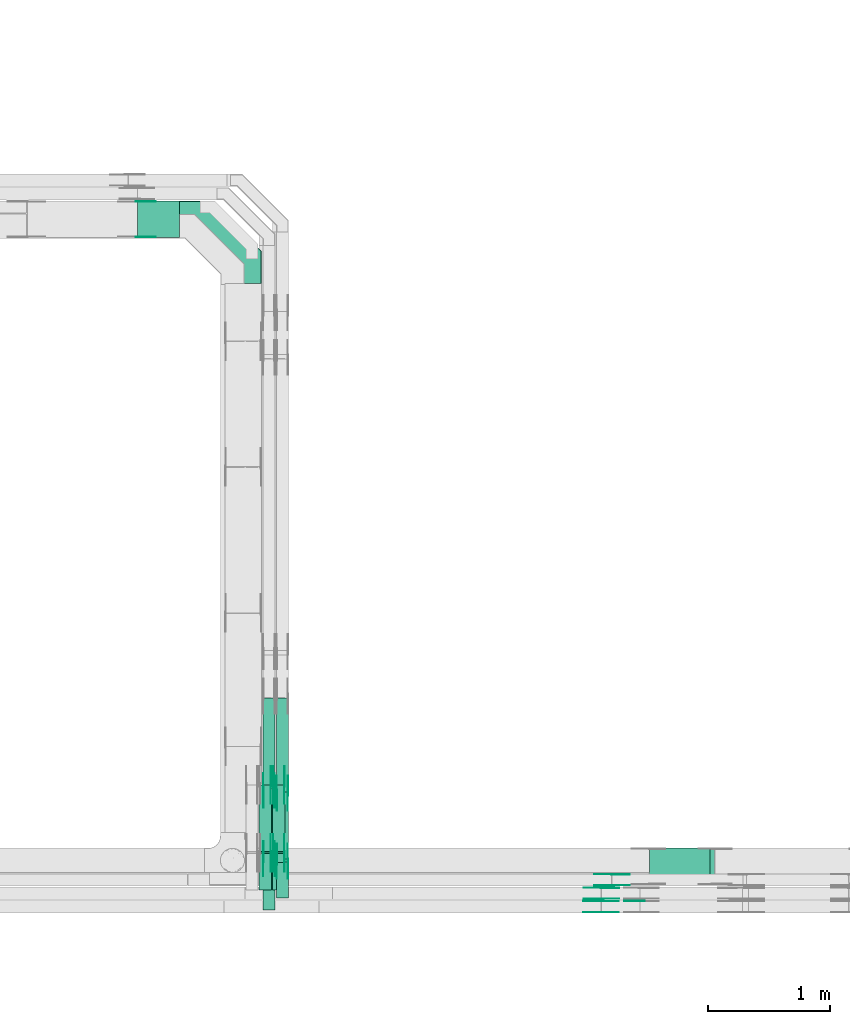
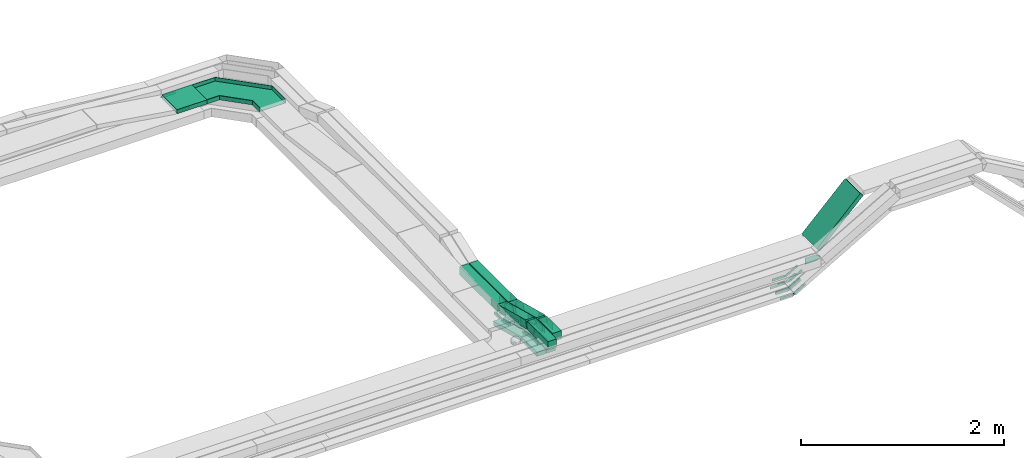
# One storey, part 25 of 33: 44 flow fittings, 12 flow segments.
"""IFC2X3 building model written with IfcOpenShell, lengths in millimetres."""

from ifc_helpers import new_model, entity, si_unit, converted_unit, derived_unit, direction, frame, frame_2d, origin, place, context, subcontext, project, spatial, polyline, circle_curve, parameter, trimmed, segment, composite_curve, rectangle, outline, extrude, faceted_brep, source, transform, mapped, material, type_object, type_shapes, element, save


model = new_model("IFC2X3")

# Units and contexts
model_context = context("Model", 3, precision=0.01, world=origin(), true_north=direction((6.12303176911189e-17, 1.0)))
body_context = subcontext(model_context, "Body", "Model", "MODEL_VIEW")
ifc_project = project(units=[si_unit("LENGTHUNIT", "METRE", prefix="MILLI"), si_unit("AREAUNIT", "SQUARE_METRE"), si_unit("VOLUMEUNIT", "CUBIC_METRE"), converted_unit("PLANEANGLEUNIT", "DEGREE", entity("IfcRatioMeasure", 0.0174532925199433), si_unit("PLANEANGLEUNIT", "RADIAN"), dimensions=[0, 0, 0, 0, 0, 0, 0]), si_unit("MASSUNIT", "GRAM", prefix="KILO"), derived_unit("MASSDENSITYUNIT", [(si_unit("MASSUNIT", "GRAM", prefix="KILO"), 1), (si_unit("LENGTHUNIT", "METRE"), -3)]), derived_unit("MOMENTOFINERTIAUNIT", [(si_unit("LENGTHUNIT", "METRE"), 4)]), si_unit("TIMEUNIT", "SECOND"), si_unit("FREQUENCYUNIT", "HERTZ"), si_unit("THERMODYNAMICTEMPERATUREUNIT", "DEGREE_CELSIUS"), derived_unit("THERMALTRANSMITTANCEUNIT", [(si_unit("MASSUNIT", "GRAM", prefix="KILO"), 1), (si_unit("THERMODYNAMICTEMPERATUREUNIT", "KELVIN"), -1), (si_unit("TIMEUNIT", "SECOND"), -3)]), derived_unit("VOLUMETRICFLOWRATEUNIT", [(si_unit("LENGTHUNIT", "METRE"), 3), (si_unit("TIMEUNIT", "SECOND"), -1)]), derived_unit("MASSFLOWRATEUNIT", [(si_unit("MASSUNIT", "GRAM", prefix="KILO"), 1), (si_unit("TIMEUNIT", "SECOND"), -1)]), derived_unit("ROTATIONALFREQUENCYUNIT", [(si_unit("TIMEUNIT", "SECOND"), -1)]), si_unit("ELECTRICCURRENTUNIT", "AMPERE"), si_unit("ELECTRICVOLTAGEUNIT", "VOLT"), si_unit("POWERUNIT", "WATT"), si_unit("FORCEUNIT", "NEWTON", prefix="KILO"), si_unit("ILLUMINANCEUNIT", "LUX"), si_unit("LUMINOUSFLUXUNIT", "LUMEN"), si_unit("LUMINOUSINTENSITYUNIT", "CANDELA"), derived_unit("USERDEFINED", [(si_unit("MASSUNIT", "GRAM", prefix="KILO"), -1), (si_unit("LENGTHUNIT", "METRE"), -2), (si_unit("TIMEUNIT", "SECOND"), 3), (si_unit("LUMINOUSFLUXUNIT", "LUMEN"), 1)]), derived_unit("LINEARVELOCITYUNIT", [(si_unit("LENGTHUNIT", "METRE"), 1), (si_unit("TIMEUNIT", "SECOND"), -1)]), si_unit("PRESSUREUNIT", "PASCAL"), derived_unit("USERDEFINED", [(si_unit("LENGTHUNIT", "METRE"), -2), (si_unit("MASSUNIT", "GRAM", prefix="KILO"), 1), (si_unit("TIMEUNIT", "SECOND"), -2)]), derived_unit("LINEARFORCEUNIT", [(si_unit("MASSUNIT", "GRAM", prefix="KILO"), 1), (si_unit("LENGTHUNIT", "METRE"), 1), (si_unit("TIMEUNIT", "SECOND"), -2), (si_unit("LENGTHUNIT", "METRE"), -1)]), derived_unit("PLANARFORCEUNIT", [(si_unit("MASSUNIT", "GRAM", prefix="KILO"), 1), (si_unit("LENGTHUNIT", "METRE"), 1), (si_unit("TIMEUNIT", "SECOND"), -2), (si_unit("LENGTHUNIT", "METRE"), -2)])], contexts=[model_context])

# Site, building, storey
site_placement = place(None, frame((0.0, -0.00077364408347762, 0.0)))
site = spatial("IfcSite", under=ifc_project, at=site_placement, CompositionType="ELEMENT")
building_placement = place(site_placement, origin())
building = spatial("IfcBuilding", under=site, at=building_placement, CompositionType="ELEMENT")
storey_placement = place(building_placement, frame((0.0, 0.0, 8100.0)))
storey = spatial("IfcBuildingStorey", under=building, at=storey_placement, CompositionType="ELEMENT", Elevation=8100.0)

# Flow segments
cable_carrier_segment_type = type_object("IfcCableCarrierSegmentType", PredefinedType="CABLETRAYSEGMENT")
flow_segment_1_placement = place(storey_placement, frame((63784.3788258892, 8869.97860618826, 2805.44313627274)))
element("IfcFlowSegment", 1, at=flow_segment_1_placement, inside=storey, type_object=cable_carrier_segment_type, context=body_context, shape_type="SweptSolid", body=[
    extrude(rectangle(XDim=50.000000000011, YDim=299.999999999999, at=frame_2d((-7.65609797781508e-13, 0.0), x_axis=(1.0, 0.0))), frame((17.6776695296773, 150.0, 17.6776695296687), z_axis=(0.707106781186504, 0.0, 0.707106781186591), x_axis=(-0.707106781186591, 0.0, 0.707106781186504)), (0.0, 0.0, 1.0), 699.790262425115),
])
flow_segment_2_placement = place(storey_placement, frame((60610.1085349485, 8663.58444205874, 2864.77838120979)))
element("IfcFlowSegment", 2, at=flow_segment_2_placement, inside=storey, type_object=cable_carrier_segment_type, context=body_context, shape_type="SweptSolid", body=[
    extrude(rectangle(XDim=409.510534279909, YDim=99.9999999999946, at=frame_2d((5.40012479177676e-13, 8.66506866259442e-12), x_axis=(1.0, 0.0))), frame((50.0, 204.755267139955, 0.0), z_axis=(0.0, 0.0, 1.0), x_axis=(0.0, -1.0, 0.0)), (0.0, 0.0, 1.0), 99.9999999999989),
])
flow_segment_3_placement = place(storey_placement, frame((60610.1085349485, 9076.08577980001, 2718.78565933378)))
element("IfcFlowSegment", 3, at=flow_segment_3_placement, inside=storey, type_object=cable_carrier_segment_type, context=body_context, shape_type="SweptSolid", body=[
    extrude(rectangle(XDim=99.9999999999971, YDim=99.9999999999946, at=frame_2d((-8.66506866259442e-12, 0.0), x_axis=(0.0, 1.0))), frame((50.0, 12.8016957729536, 193.93674912082), z_axis=(0.0, 0.966667799264408, -0.25603391545908), x_axis=(-1.0, 0.0, 0.0)), (0.0, 0.0, 1.0), 568.687780665809),
])
flow_segment_4_placement = place(storey_placement, frame((60720.1085349485, 8762.62949966908, 2864.81248367712)))
element("IfcFlowSegment", 4, at=flow_segment_4_placement, inside=storey, type_object=cable_carrier_segment_type, context=body_context, shape_type="SweptSolid", body=[
    extrude(rectangle(XDim=289.519566739919, YDim=99.9999999999946, at=frame_2d((5.40012479177676e-13, 8.66506866259442e-12), x_axis=(1.0, 0.0))), frame((50.0, 144.759783369959, 0.0), z_axis=(0.0, 0.0, 1.0), x_axis=(0.0, -1.0, 0.0)), (0.0, 0.0, 1.0), 99.9999999999989),
])
flow_segment_5_placement = place(storey_placement, frame((60720.1085349485, 9055.13986987036, 2718.82215415974)))
element("IfcFlowSegment", 5, at=flow_segment_5_placement, inside=storey, type_object=cable_carrier_segment_type, context=body_context, shape_type="SweptSolid", body=[
    extrude(rectangle(XDim=99.9999999999987, YDim=99.9999999999946, at=frame_2d((-8.66506866259442e-12, 0.0), x_axis=(0.0, 1.0))), frame((50.0, 12.8016957729579, 193.934356762171), z_axis=(0.0, 0.966667799264392, -0.25603391545914), x_axis=(-1.0, 0.0, 0.0)), (0.0, 0.0, 1.0), 568.678436752631),
])
flow_segment_6_placement = place(storey_placement, frame((60720.1085349493, 9633.45677814429, 2715.09535929605)))
element("IfcFlowSegment", 6, at=flow_segment_6_placement, inside=storey, type_object=cable_carrier_segment_type, context=body_context, shape_type="SweptSolid", body=[
    extrude(rectangle(XDim=769.369188674836, YDim=99.9999999985392, at=frame_2d((-5.6843418860808e-13, 0.0), x_axis=(1.0, 0.0))), frame((50.0, 384.684594331773, 0.00208428287731977), z_axis=(0.0, 5.41816050582133e-06, 1.0), x_axis=(0.0, 1.0, -5.41816050582133e-06)), (0.0, 0.0, 1.0), 99.99999999853),
])
flow_segment_7_placement = place(storey_placement, frame((60610.1085349485, 9654.41214021207, 2715.06307654166)))
element("IfcFlowSegment", 7, at=flow_segment_7_placement, inside=storey, type_object=cable_carrier_segment_type, context=body_context, shape_type="SweptSolid", body=[
    extrude(rectangle(XDim=748.425977553941, YDim=99.9999999999946, at=frame_2d((2.18847162614111e-12, 0.0), x_axis=(1.0, 0.0))), frame((50.0, 374.212988776977, 0.0), z_axis=(0.0, 0.0, 1.0), x_axis=(0.0, -1.0, 0.0)), (0.0, 0.0, 1.0), 99.9999999999968),
])
flow_segment_8_placement = place(storey_placement, frame((60690.1085349485, 8826.02609150699, 2697.68139712069)))
element("IfcFlowSegment", 8, at=flow_segment_8_placement, inside=storey, type_object=cable_carrier_segment_type, context=body_context, shape_type="SweptSolid", body=[
    extrude(rectangle(XDim=300.444409805727, YDim=99.9999999999946, at=frame_2d((-5.40012479177676e-13, 0.0), x_axis=(1.0, 0.0))), frame((50.0, 150.222204902864, 0.0), z_axis=(0.0, 0.0, 1.0), x_axis=(0.0, -1.0, 0.0)), (0.0, 0.0, 1.0), 50.0000000000016),
])
flow_segment_9_placement = place(storey_placement, frame((60690.1085349485, 9129.46130477396, 2552.05597275502)))
element("IfcFlowSegment", 9, at=flow_segment_9_placement, inside=storey, type_object=cable_carrier_segment_type, context=body_context, shape_type="SweptSolid", body=[
    extrude(rectangle(XDim=50.0000000000033, YDim=567.25321482059, at=frame_2d((0.0, 0.0), x_axis=(0.0, 1.0))), frame((0.0, 280.573556284615, 96.7847258052534), z_axis=(1.0, 0.0, 0.0), x_axis=(0.0, 0.966667799264399, -0.256033915459111)), (0.0, 0.0, 1.0), 99.9999999999946),
])
flow_segment_10_placement = place(storey_placement, frame((60580.1085349485, 8826.02609150699, 2697.68139712068)))
element("IfcFlowSegment", 10, at=flow_segment_10_placement, inside=storey, type_object=cable_carrier_segment_type, context=body_context, shape_type="SweptSolid", body=[
    extrude(rectangle(XDim=300.444409805722, YDim=99.9999999999946, at=frame_2d((-5.40012479177676e-13, 0.0), x_axis=(1.0, 0.0))), frame((50.0, 150.222204902862, 0.0), z_axis=(0.0, 0.0, 1.0), x_axis=(0.0, -1.0, 0.0)), (0.0, 0.0, 1.0), 50.0000000000016),
])
flow_segment_11_placement = place(storey_placement, frame((60580.1085349485, 9129.46130477395, 2552.055972755)))
element("IfcFlowSegment", 11, at=flow_segment_11_placement, inside=storey, type_object=cable_carrier_segment_type, context=body_context, shape_type="SweptSolid", body=[
    extrude(rectangle(XDim=50.0000000000033, YDim=567.253214820593, at=frame_2d((5.40012479177676e-13, 1.4033219031262e-13), x_axis=(0.0, 1.0))), frame((0.0, 280.573556284615, 96.7847258052534), z_axis=(1.0, 0.0, 0.0), x_axis=(0.0, 0.9666677992644, -0.256033915459109)), (0.0, 0.0, 1.0), 99.9999999999946),
])
flow_segment_12_placement = place(storey_placement, frame((59581.8230685685, 14182.2782357481, 2714.71648655331)))
element("IfcFlowSegment", 12, at=flow_segment_12_placement, inside=storey, type_object=cable_carrier_segment_type, context=body_context, shape_type="SweptSolid", body=[
    extrude(rectangle(XDim=342.285466379996, YDim=300.000000000001, at=frame_2d((0.0, -1.08002495835535e-12), x_axis=(1.0, 0.0))), frame((171.142733189998, 150.0, 0.0)), (0.0, 0.0, 1.0), 50.0000000000016),
])

# Flow fittings
ifc_material_1 = material(Name="G")
cable_carrier_fitting_type_1 = type_object("IfcCableCarrierFittingType", PredefinedType="NOTDEFINED", material=ifc_material_1)
shared_shape_1 = source(origin(), body_context, "Body", "SweptSolid", [
    extrude(outline(composite_curve([segment(trimmed(circle_curve(frame_2d((-44.5901162790698, 0.0), x_axis=(1.0, 0.0)), 12.5), [parameter(90.0000000000007)], [parameter(270.0)], True, "PARAMETER"), True, "CONTINUOUS"), segment(polyline([(-44.5901162790697, -12.5), (-33.0901162790698, -12.5)]), True, "CONTINUOUS"), segment(polyline([(-33.0901162790698, -12.5), (-31.2296511627907, -14.5)]), True, "CONTINUOUS"), segment(polyline([(-31.2296511627907, -14.5), (108.90988372093, -14.5)]), True, "CONTINUOUS"), segment(polyline([(108.90988372093, -14.5), (108.90988372093, 14.5)]), True, "CONTINUOUS"), segment(polyline([(108.90988372093, 14.5), (-31.2296511627907, 14.5)]), True, "CONTINUOUS"), segment(polyline([(-31.2296511627907, 14.5), (-33.0901162790698, 12.5)]), True, "CONTINUOUS"), segment(polyline([(-33.0901162790698, 12.5), (-44.5901162790699, 12.5)]), True, "CONTINUOUS")], self_intersect=False)), frame((44.5901162790698, 0.0, 0.0), z_axis=(0.0, 0.0, -1.0), x_axis=(1.0, 0.0, 0.0)), (0.0, 0.0, -1.0), 2.0),
])
type_shapes(cable_carrier_fitting_type_1, [shared_shape_1])
for number, where, z_axis, x_axis in (
    (13, (60785.5685349586, 9131.2459145021, 2722.68139712075), (1.0, 0.0, 0.0), (0.0, -1.0, 0.0)),
    (14, (60675.5685349586, 9131.2459145021, 2722.68139712074), (1.0, 0.0, 0.0), (0.0, -1.0, 0.0)),
    (15, (60675.5685349586, 9688.82380761497, 2575.0), (1.0, 0.0, 0.0), (0.0, 1.0, 0.0)),
    (16, (60785.5685349586, 9688.82380761497, 2575.0), (1.0, 0.0, 0.0), (0.0, 1.0, 0.0)),
    (17, (63481.7964990867, 8955.43860619837, 2574.87332137862), (0.0, 1.0, 0.0), (-1.0, 0.0, 0.0)),
    (18, (63395.1341032399, 8845.43860619837, 2574.8693455352), (0.0, 1.0, 0.0), (-1.0, 0.0, 0.0)),
    (19, (63392.1739116772, 8735.44005286093, 2573.15905189633), (0.0, 1.0, 0.0), (-1.0, 0.0, 0.0)),
    (20, (59578.6062108725, 14186.818235738, 2739.7164865533), (0.0, -1.0, 0.0), (1.0, 0.0, 0.0)),
):
    element("IfcFlowFitting", number, at=place(storey_placement, frame(where, z_axis=z_axis, x_axis=x_axis)), inside=storey, type_object=cable_carrier_fitting_type_1, material=ifc_material_1, context=body_context, shape_type="MappedRepresentation", body=[
        mapped(shared_shape_1, transform((0.0, 0.0, 0.0), scale=1.0)),
    ])
cable_carrier_fitting_type_2 = type_object("IfcCableCarrierFittingType", PredefinedType="NOTDEFINED", material=ifc_material_1)
shared_shape_2 = source(origin(), body_context, "Body", "SweptSolid", [
    extrude(outline(composite_curve([segment(trimmed(circle_curve(frame_2d((-44.5901162790697, 0.0), x_axis=(1.0, 0.0)), 12.5), [parameter(90.0000000000007)], [parameter(270.0)], True, "PARAMETER"), True, "CONTINUOUS"), segment(polyline([(-44.5901162790697, -12.5), (-33.0901162790697, -12.5)]), True, "CONTINUOUS"), segment(polyline([(-33.0901162790697, -12.5), (-31.2296511627907, -14.5)]), True, "CONTINUOUS"), segment(polyline([(-31.2296511627907, -14.5), (108.90988372093, -14.5)]), True, "CONTINUOUS"), segment(polyline([(108.90988372093, -14.5), (108.90988372093, 14.5)]), True, "CONTINUOUS"), segment(polyline([(108.90988372093, 14.5), (-31.2296511627907, 14.5)]), True, "CONTINUOUS"), segment(polyline([(-31.2296511627907, 14.5), (-33.0901162790698, 12.5)]), True, "CONTINUOUS"), segment(polyline([(-33.0901162790698, 12.5), (-44.5901162790699, 12.5)]), True, "CONTINUOUS")], self_intersect=False)), frame((44.5901162790697, 0.0, 0.0)), (0.0, 0.0, 1.0), 2.0),
])
type_shapes(cable_carrier_fitting_type_2, [shared_shape_2])
for number, where, z_axis, x_axis in (
    (21, (60694.6485349383, 9131.24591450211, 2722.68139712076), (-1.0, 0.0, 0.0), (0.0, -1.0, 0.0)),
    (22, (60694.6485349383, 9688.82380761497, 2575.0), (-1.0, 0.0, 0.0), (0.0, 1.0, 0.0)),
    (23, (63481.7964990867, 8864.51860617805, 2574.87332137861), (0.0, -1.0, 0.0), (-1.0, 0.0, 0.0)),
    (24, (63395.1341032399, 8754.51860617806, 2574.8693455352), (0.0, -1.0, 0.0), (-1.0, 0.0, 0.0)),
    (25, (63392.1739116772, 8644.52005284061, 2573.15905189633), (0.0, -1.0, 0.0), (-1.0, 0.0, 0.0)),
    (26, (59578.6062108725, 14477.7382357583, 2739.7164865533), (0.0, 1.0, 0.0), (1.0, 0.0, 0.0)),
):
    element("IfcFlowFitting", number, at=place(storey_placement, frame(where, z_axis=z_axis, x_axis=x_axis)), inside=storey, type_object=cable_carrier_fitting_type_2, material=ifc_material_1, context=body_context, shape_type="MappedRepresentation", body=[
        mapped(shared_shape_2, transform((0.0, 0.0, 0.0), scale=1.0)),
    ])
cable_carrier_fitting_type_3 = type_object("IfcCableCarrierFittingType", PredefinedType="NOTDEFINED", material=ifc_material_1)
shared_shape_3 = source(origin(), body_context, "Body", "SweptSolid", [
    extrude(outline(composite_curve([segment(trimmed(circle_curve(frame_2d((-44.5901162790698, 0.0), x_axis=(1.0, 0.0)), 12.5), [parameter(90.0000000000007)], [parameter(270.0)], True, "PARAMETER"), True, "CONTINUOUS"), segment(polyline([(-44.5901162790697, -12.5), (-33.0901162790698, -12.5)]), True, "CONTINUOUS"), segment(polyline([(-33.0901162790698, -12.5), (-31.2296511627907, -14.5)]), True, "CONTINUOUS"), segment(polyline([(-31.2296511627907, -14.5), (108.90988372093, -14.5)]), True, "CONTINUOUS"), segment(polyline([(108.90988372093, -14.5), (108.90988372093, 14.5)]), True, "CONTINUOUS"), segment(polyline([(108.90988372093, 14.5), (-31.2296511627907, 14.5)]), True, "CONTINUOUS"), segment(polyline([(-31.2296511627907, 14.5), (-33.0901162790698, 12.5)]), True, "CONTINUOUS"), segment(polyline([(-33.0901162790698, 12.5), (-44.5901162790699, 12.5)]), True, "CONTINUOUS")], self_intersect=False)), frame((44.5901162790698, 0.0, 0.0), z_axis=(0.0, 0.0, -1.0), x_axis=(1.0, 0.0, 0.0)), (0.0, 0.0, -1.0), 2.0),
])
type_shapes(cable_carrier_fitting_type_3, [shared_shape_3])
for number, where, z_axis, x_axis in (
    (27, (60696.6485349383, 9131.24591450209, 2722.68139712076), (-1.0, 0.0, 0.0), (0.0, 0.966667799263134, -0.256033915463888)),
    (28, (60696.6485349383, 9688.82380761499, 2575.0), (-1.0, 0.0, 0.0), (0.0, -0.966667799264405, 0.256033915459091)),
    (29, (63481.7964990867, 8866.51860617805, 2574.87332137861), (0.0, -1.0, 0.0), (0.866025403784435, 0.0, 0.500000000000007)),
    (30, (63395.1341032399, 8756.51860617806, 2574.8693455352), (0.0, -1.0, 0.0), (0.866025403784431, 0.0, 0.500000000000014)),
    (31, (63392.1739116772, 8646.52005284061, 2573.15905189633), (0.0, -1.0, 0.0), (0.866025403784416, 0.0, 0.500000000000039)),
):
    element("IfcFlowFitting", number, at=place(storey_placement, frame(where, z_axis=z_axis, x_axis=x_axis)), inside=storey, type_object=cable_carrier_fitting_type_3, material=ifc_material_1, context=body_context, shape_type="MappedRepresentation", body=[
        mapped(shared_shape_3, transform((0.0, 0.0, 0.0), scale=1.0)),
    ])
cable_carrier_fitting_type_4 = type_object("IfcCableCarrierFittingType", PredefinedType="NOTDEFINED", material=ifc_material_1)
shared_shape_4 = source(origin(), body_context, "Body", "SweptSolid", [
    extrude(outline(composite_curve([segment(trimmed(circle_curve(frame_2d((-44.5901162790697, 0.0), x_axis=(1.0, 0.0)), 12.5), [parameter(90.0000000000007)], [parameter(270.0)], True, "PARAMETER"), True, "CONTINUOUS"), segment(polyline([(-44.5901162790697, -12.5), (-33.0901162790697, -12.5)]), True, "CONTINUOUS"), segment(polyline([(-33.0901162790697, -12.5), (-31.2296511627907, -14.5)]), True, "CONTINUOUS"), segment(polyline([(-31.2296511627907, -14.5), (108.90988372093, -14.5)]), True, "CONTINUOUS"), segment(polyline([(108.90988372093, -14.5), (108.90988372093, 14.5)]), True, "CONTINUOUS"), segment(polyline([(108.90988372093, 14.5), (-31.2296511627907, 14.5)]), True, "CONTINUOUS"), segment(polyline([(-31.2296511627907, 14.5), (-33.0901162790698, 12.5)]), True, "CONTINUOUS"), segment(polyline([(-33.0901162790698, 12.5), (-44.5901162790699, 12.5)]), True, "CONTINUOUS")], self_intersect=False)), frame((44.5901162790697, 0.0, 0.0)), (0.0, 0.0, 1.0), 2.0),
])
type_shapes(cable_carrier_fitting_type_4, [shared_shape_4])
for number, where, z_axis, x_axis in (
    (32, (60783.5685349586, 9131.24591450209, 2722.68139712075), (1.0, 0.0, 0.0), (0.0, 0.966667799263134, -0.256033915463888)),
    (33, (60673.5685349586, 9131.24591450208, 2722.68139712073), (1.0, 0.0, 0.0), (0.0, 0.966667799263134, -0.256033915463888)),
    (34, (60673.5685349586, 9688.82380761499, 2575.0), (1.0, 0.0, 0.0), (0.0, -0.966667799264405, 0.256033915459089)),
    (35, (60783.5685349586, 9688.82380761499, 2575.0), (1.0, 0.0, 0.0), (0.0, -0.966667799264405, 0.256033915459091)),
    (36, (63481.7964990867, 8953.43860619837, 2574.87332137862), (0.0, 1.0, 0.0), (0.866025403784435, 0.0, 0.500000000000007)),
    (37, (63395.1341032399, 8843.43860619837, 2574.8693455352), (0.0, 1.0, 0.0), (0.866025403784431, 0.0, 0.500000000000014)),
    (38, (63392.1739116772, 8733.44005286093, 2573.15905189633), (0.0, 1.0, 0.0), (0.866025403784416, 0.0, 0.500000000000039)),
):
    element("IfcFlowFitting", number, at=place(storey_placement, frame(where, z_axis=z_axis, x_axis=x_axis)), inside=storey, type_object=cable_carrier_fitting_type_4, material=ifc_material_1, context=body_context, shape_type="MappedRepresentation", body=[
        mapped(shared_shape_4, transform((0.0, 0.0, 0.0), scale=1.0)),
    ])
cable_carrier_fitting_type_5 = type_object("IfcCableCarrierFittingType", PredefinedType="NOTDEFINED", material=ifc_material_1)
shared_shape_5 = source(origin(), body_context, "Body", "SweptSolid", [
    extrude(outline(composite_curve([segment(trimmed(circle_curve(frame_2d((-41.4651162790697, 0.0), x_axis=(1.0, 0.0)), 25.0), [parameter(90.0000000000007)], [parameter(270.0)], True, "PARAMETER"), True, "CONTINUOUS"), segment(polyline([(-41.4651162790697, -25.0), (-29.9651162790697, -25.0)]), True, "CONTINUOUS"), segment(polyline([(-29.9651162790697, -25.0), (-28.1046511627907, -38.5)]), True, "CONTINUOUS"), segment(polyline([(-28.1046511627907, -38.5), (99.5348837209303, -38.5)]), True, "CONTINUOUS"), segment(polyline([(99.5348837209303, -38.5), (99.5348837209303, 38.5)]), True, "CONTINUOUS"), segment(polyline([(99.5348837209303, 38.5), (-28.1046511627907, 38.5)]), True, "CONTINUOUS"), segment(polyline([(-28.1046511627907, 38.5), (-29.9651162790697, 25.0)]), True, "CONTINUOUS"), segment(polyline([(-29.9651162790697, 25.0), (-41.46511627907, 25.0)]), True, "CONTINUOUS")], self_intersect=False)), frame((41.4651162790697, 0.0, 0.0), z_axis=(0.0, 0.0, -1.0), x_axis=(1.0, 0.0, 0.0)), (0.0, 0.0, -1.0), 2.0),
])
type_shapes(cable_carrier_fitting_type_5, [shared_shape_5])
for number, where, z_axis, x_axis in (
    (39, (60705.5685349587, 9081.1250560706, 2914.77838120986), (1.0, 0.0, 0.0), (0.0, -1.0, 0.0)),
    (40, (60815.5685349587, 9060.17914614095, 2914.81248367717), (1.0, 0.0, 0.0), (0.0, -1.0, 0.0)),
    (41, (60705.5685349587, 9646.38206048012, 2765.06307654178), (1.0, 0.0, 0.0), (0.0, 1.0, 0.0)),
    (42, (60815.5685349587, 9625.42711809031, 2765.09957136777), (1.0, 0.0, 0.0), (0.0, 1.0, -5.41816542959372e-06)),
    (43, (63717.4196649966, 8735.43859023208, 2849.49286701191), (0.0, 1.0, 0.0), (-1.0, 0.0, 0.0)),
):
    element("IfcFlowFitting", number, at=place(storey_placement, frame(where, z_axis=z_axis, x_axis=x_axis)), inside=storey, type_object=cable_carrier_fitting_type_5, material=ifc_material_1, context=body_context, shape_type="MappedRepresentation", body=[
        mapped(shared_shape_5, transform((0.0, 0.0, 0.0), scale=1.0)),
    ])
cable_carrier_fitting_type_6 = type_object("IfcCableCarrierFittingType", PredefinedType="NOTDEFINED", material=ifc_material_1)
shared_shape_6 = source(origin(), body_context, "Body", "SweptSolid", [
    extrude(outline(composite_curve([segment(trimmed(circle_curve(frame_2d((-41.4651162790697, 0.0), x_axis=(1.0, 0.0)), 25.0), [parameter(90.0000000000007)], [parameter(270.0)], True, "PARAMETER"), True, "CONTINUOUS"), segment(polyline([(-41.4651162790697, -25.0), (-29.9651162790697, -25.0)]), True, "CONTINUOUS"), segment(polyline([(-29.9651162790697, -25.0), (-28.1046511627907, -38.5)]), True, "CONTINUOUS"), segment(polyline([(-28.1046511627907, -38.5), (99.5348837209303, -38.5)]), True, "CONTINUOUS"), segment(polyline([(99.5348837209303, -38.5), (99.5348837209303, 38.5)]), True, "CONTINUOUS"), segment(polyline([(99.5348837209303, 38.5), (-28.1046511627907, 38.5)]), True, "CONTINUOUS"), segment(polyline([(-28.1046511627907, 38.5), (-29.9651162790697, 25.0)]), True, "CONTINUOUS"), segment(polyline([(-29.9651162790697, 25.0), (-41.46511627907, 25.0)]), True, "CONTINUOUS")], self_intersect=False)), frame((41.4651162790697, 0.0, 0.0)), (0.0, 0.0, 1.0), 2.0),
])
type_shapes(cable_carrier_fitting_type_6, [shared_shape_6])
for number, where, z_axis, x_axis in (
    (44, (60614.6485349384, 9081.1250560706, 2914.77838120988), (-1.0, 0.0, 0.0), (0.0, -1.0, 0.0)),
    (45, (60724.6485349384, 9060.17914614095, 2914.81248367719), (-1.0, 0.0, 0.0), (0.0, -1.0, 0.0)),
    (46, (60614.6485349384, 9646.38206048012, 2765.06307654178), (-1.0, 0.0, 0.0), (0.0, 1.0, 0.0)),
    (47, (60724.6485349384, 9625.42711809031, 2765.09957136777), (-1.0, 0.0, 0.0), (0.0, 1.0, -5.41816542959372e-06)),
):
    element("IfcFlowFitting", number, at=place(storey_placement, frame(where, z_axis=z_axis, x_axis=x_axis)), inside=storey, type_object=cable_carrier_fitting_type_6, material=ifc_material_1, context=body_context, shape_type="MappedRepresentation", body=[
        mapped(shared_shape_6, transform((0.0, 0.0, 0.0), scale=1.0)),
    ])
cable_carrier_fitting_type_7 = type_object("IfcCableCarrierFittingType", PredefinedType="NOTDEFINED", material=ifc_material_1)
shared_shape_7 = source(origin(), body_context, "Body", "SweptSolid", [
    extrude(outline(composite_curve([segment(trimmed(circle_curve(frame_2d((-41.4651162790697, 0.0), x_axis=(1.0, 0.0)), 25.0), [parameter(90.0000000000007)], [parameter(270.0)], True, "PARAMETER"), True, "CONTINUOUS"), segment(polyline([(-41.4651162790697, -25.0), (-29.9651162790697, -25.0)]), True, "CONTINUOUS"), segment(polyline([(-29.9651162790697, -25.0), (-28.1046511627907, -38.5)]), True, "CONTINUOUS"), segment(polyline([(-28.1046511627907, -38.5), (99.5348837209303, -38.5)]), True, "CONTINUOUS"), segment(polyline([(99.5348837209303, -38.5), (99.5348837209303, 38.5)]), True, "CONTINUOUS"), segment(polyline([(99.5348837209303, 38.5), (-28.1046511627907, 38.5)]), True, "CONTINUOUS"), segment(polyline([(-28.1046511627907, 38.5), (-29.9651162790697, 25.0)]), True, "CONTINUOUS"), segment(polyline([(-29.9651162790697, 25.0), (-41.46511627907, 25.0)]), True, "CONTINUOUS")], self_intersect=False)), frame((41.4651162790697, 0.0, 0.0), z_axis=(0.0, 0.0, -1.0), x_axis=(1.0, 0.0, 0.0)), (0.0, 0.0, -1.0), 2.0),
])
type_shapes(cable_carrier_fitting_type_7, [shared_shape_7])
for number, where, z_axis, x_axis in (
    (48, (60616.6485349384, 9081.12505607058, 2914.77838120988), (-1.0, 0.0, 0.0), (0.0, 0.966667799263134, -0.256033915463888)),
    (49, (60726.6485349384, 9060.17914614093, 2914.81248367718), (-1.0, 0.0, 0.0), (0.0, 0.966667799263134, -0.256033915463888)),
    (50, (60616.6485349384, 9646.38206048014, 2765.06307654178), (-1.0, 0.0, 0.0), (0.0, -0.966667799264413, 0.256033915459061)),
    (51, (60726.6485349384, 9625.42711809033, 2765.09957136777), (-1.0, 0.0, 0.0), (0.0, -0.966667799264395, 0.256033915459125)),
):
    element("IfcFlowFitting", number, at=place(storey_placement, frame(where, z_axis=z_axis, x_axis=x_axis)), inside=storey, type_object=cable_carrier_fitting_type_7, material=ifc_material_1, context=body_context, shape_type="MappedRepresentation", body=[
        mapped(shared_shape_7, transform((0.0, 0.0, 0.0), scale=1.0)),
    ])
cable_carrier_fitting_type_8 = type_object("IfcCableCarrierFittingType", PredefinedType="NOTDEFINED", material=ifc_material_1)
shared_shape_8 = source(origin(), body_context, "Body", "SweptSolid", [
    extrude(outline(composite_curve([segment(trimmed(circle_curve(frame_2d((-41.4651162790697, 0.0), x_axis=(1.0, 0.0)), 25.0), [parameter(90.0000000000007)], [parameter(270.0)], True, "PARAMETER"), True, "CONTINUOUS"), segment(polyline([(-41.4651162790697, -25.0), (-29.9651162790697, -25.0)]), True, "CONTINUOUS"), segment(polyline([(-29.9651162790697, -25.0), (-28.1046511627907, -38.5)]), True, "CONTINUOUS"), segment(polyline([(-28.1046511627907, -38.5), (99.5348837209303, -38.5)]), True, "CONTINUOUS"), segment(polyline([(99.5348837209303, -38.5), (99.5348837209303, 38.5)]), True, "CONTINUOUS"), segment(polyline([(99.5348837209303, 38.5), (-28.1046511627907, 38.5)]), True, "CONTINUOUS"), segment(polyline([(-28.1046511627907, 38.5), (-29.9651162790697, 25.0)]), True, "CONTINUOUS"), segment(polyline([(-29.9651162790697, 25.0), (-41.46511627907, 25.0)]), True, "CONTINUOUS")], self_intersect=False)), frame((41.4651162790697, 0.0, 0.0)), (0.0, 0.0, 1.0), 2.0),
])
type_shapes(cable_carrier_fitting_type_8, [shared_shape_8])
for number, where, z_axis, x_axis in (
    (52, (60703.5685349587, 9081.12505607058, 2914.77838120986), (1.0, 0.0, 0.0), (0.0, 0.966667799263134, -0.256033915463888)),
    (53, (60813.5685349587, 9060.17914614093, 2914.81248367717), (1.0, 0.0, 0.0), (0.0, 0.966667799263134, -0.256033915463888)),
    (54, (60703.5685349587, 9646.38206048014, 2765.06307654178), (1.0, 0.0, 0.0), (0.0, -0.966667799264413, 0.256033915459061)),
    (55, (60813.5685349587, 9625.42711809033, 2765.09957136777), (1.0, 0.0, 0.0), (0.0, -0.966667799264395, 0.256033915459125)),
):
    element("IfcFlowFitting", number, at=place(storey_placement, frame(where, z_axis=z_axis, x_axis=x_axis)), inside=storey, type_object=cable_carrier_fitting_type_8, material=ifc_material_1, context=body_context, shape_type="MappedRepresentation", body=[
        mapped(shared_shape_8, transform((0.0, 0.0, 0.0), scale=1.0)),
    ])
ifc_material_2 = material()
cable_carrier_fitting_type_9 = type_object("IfcCableCarrierFittingType", Name="470_DKC_G5_Sheet horizontal bend:-", PredefinedType="NOTDEFINED", material=ifc_material_2)
shared_shape_9 = source(origin(), body_context, "Body", "Brep", [
    faceted_brep([(-526.0, -150.0, -25.0), (-526.0, -150.0, 25.0), (-526.0, -145.0, 25.0), (-526.0, -145.0, -20.0), (-526.0, 145.0, -20.0), (-526.0, 145.0, 25.0), (-526.0, 150.0, 25.0), (-526.0, 150.0, -25.0), (150.0, 526.0, -25.0), (-150.0, 526.0, -25.0), (-150.0, 526.0, 25.0), (-145.0, 526.0, 25.0), (-145.0, 526.0, -20.0), (145.0, 526.0, -20.0), (145.0, 526.0, 25.0), (150.0, 526.0, 25.0), (-262.867965644028, -150.0, -25.0), (-262.867965644028, -150.0, 25.0), (150.0, 262.867965644025, 25.0), (145.0, 264.93903345589, 25.0), (-264.939033455893, -145.0, 25.0), (-264.939033455893, -145.0, -20.0), (145.0, 264.93903345589, -20.0), (-145.0, 385.060966544088, -20.0), (-385.060966544091, 145.0, -20.0), (-385.060966544091, 145.0, 25.0), (-145.0, 385.060966544088, 25.0), (-150.0, 387.132034355953, 25.0), (-387.132034355956, 150.0, 25.0), (-387.132034355956, 150.0, -25.0), (-150.0, 387.132034355953, -25.0), (150.0, 262.867965644025, -25.0)], [[[0, 1, 2, 3, 4, 5, 6, 7]], [[8, 9, 10, 11, 12, 13, 14, 15]], [[1, 0, 16, 17]], [[2, 1, 17, 18, 15, 14, 19, 20]], [[3, 2, 20, 21]], [[4, 3, 21, 22, 13, 12, 23, 24]], [[5, 4, 24, 25]], [[6, 5, 25, 26, 11, 10, 27, 28]], [[7, 6, 28, 29]], [[0, 7, 29, 30, 9, 8, 31, 16]], [[17, 16, 31, 18]], [[21, 20, 19, 22]], [[25, 24, 23, 26]], [[29, 28, 27, 30]], [[18, 31, 8, 15]], [[22, 19, 14, 13]], [[26, 23, 12, 11]], [[30, 27, 10, 9]]]),
])
type_shapes(cable_carrier_fitting_type_9, [shared_shape_9])
flow_fitting_placement = place(storey_placement, frame((60450.1085349485, 14332.2782357481, 2739.71648655332), z_axis=(0.0, 0.0, 1.0), x_axis=(0.0, 1.0, 0.0)))
element("IfcFlowFitting", 56, at=flow_fitting_placement, inside=storey, type_object=cable_carrier_fitting_type_9, material=ifc_material_2, Name="470_DKC_G5_Sheet horizontal bend:-", ObjectType="470_DKC_G5_Sheet horizontal bend:-", context=body_context, shape_type="MappedRepresentation", body=[
    mapped(shared_shape_9, transform((0.0, 0.0, 0.0), scale=1.0)),
])

save(model, "model.ifc")
